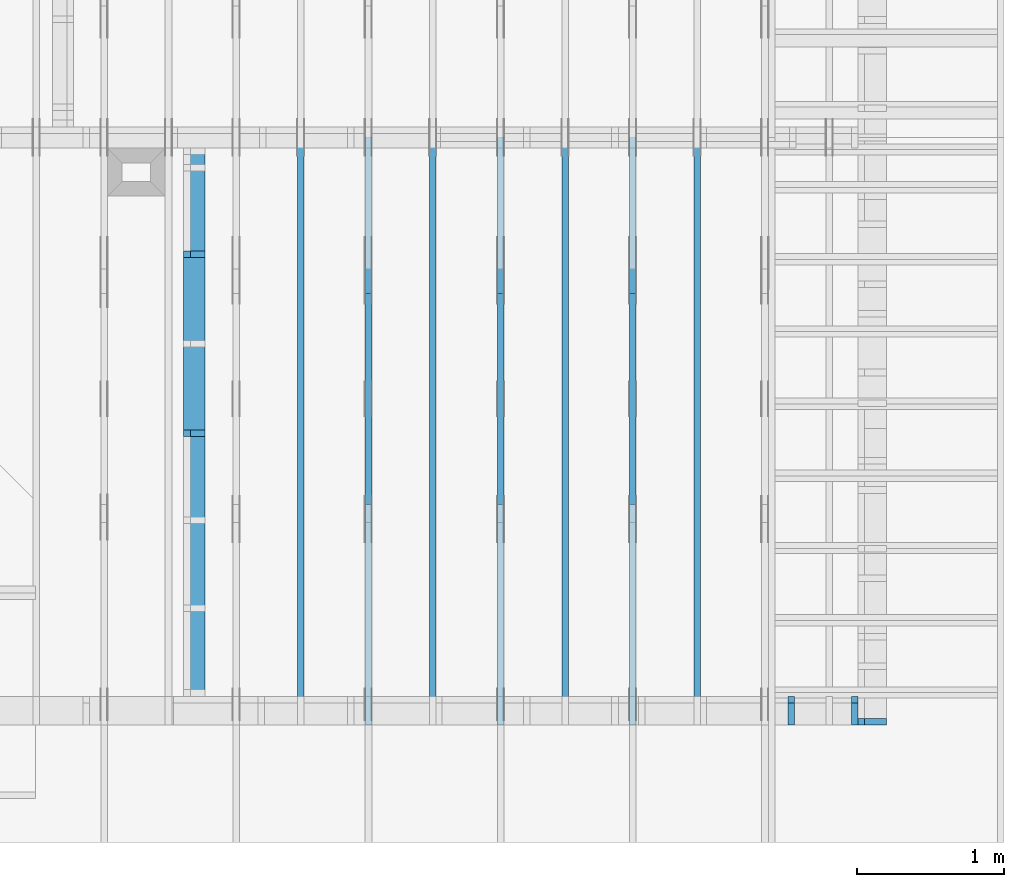
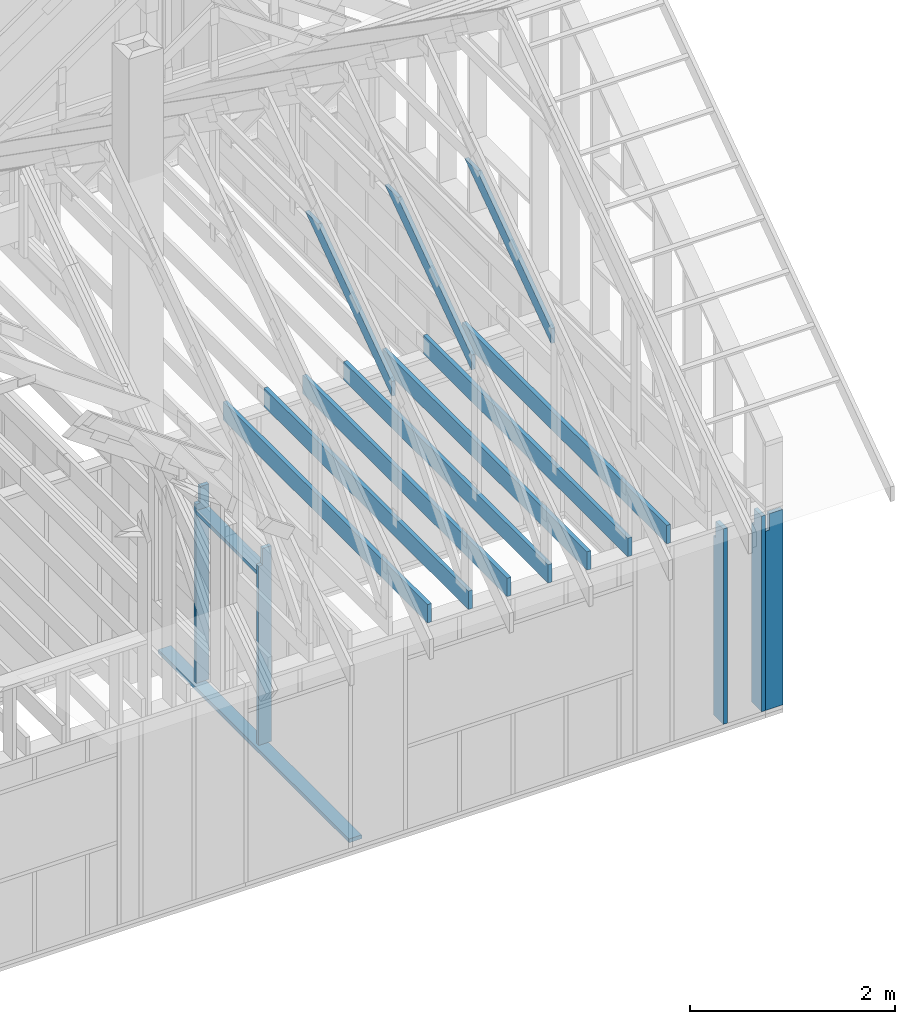
# One storey, part 21 of 70: 17 members, 10 elements without a shape of their own.
"""IFC2X3 building model written with IfcOpenShell, lengths in millimetres."""

from ifc_helpers import new_model, si_unit, frame, origin, origin_with_axes, origin_2d, place, context, project, spatial, faceted_brep, element, aggregate, save


model = new_model("IFC2X3")

# Units and contexts
model_context = context("Model", 3, precision=1e-05, world=origin())
plan_context = context("Plan", 2, precision=1e-05, world=origin_2d())
ifc_project = project(units=[si_unit("LENGTHUNIT", "METRE", prefix="MILLI"), si_unit("AREAUNIT", "SQUARE_METRE"), si_unit("VOLUMEUNIT", "CUBIC_METRE"), si_unit("SOLIDANGLEUNIT", "STERADIAN"), si_unit("PLANEANGLEUNIT", "RADIAN"), si_unit("MASSUNIT", "GRAM"), si_unit("TIMEUNIT", "SECOND"), si_unit("THERMODYNAMICTEMPERATUREUNIT", "DEGREE_CELSIUS"), si_unit("LUMINOUSINTENSITYUNIT", "LUMEN")], contexts=[model_context, plan_context])

# Site, building, storey
site_placement = place(None, origin_with_axes())
site = spatial("IfcSite", under=ifc_project, at=site_placement, CompositionType="ELEMENT")
building_placement = place(site_placement, origin_with_axes())
building = spatial("IfcBuilding", under=site, at=building_placement, Name="Layout 1", CompositionType="ELEMENT")
storey_placement = place(building_placement, origin_with_axes())
storey = spatial("IfcBuildingStorey", under=building, at=storey_placement, Name="Storey 1", CompositionType="ELEMENT", Elevation=0.0)

# Assembly, members
assembly_1_placement = place(storey_placement, frame((-48.55339059325575, 0.0, -2470.0), z_axis=(0.0, -1.0, 6.123031769111886e-17), x_axis=(1.0, 0.0, 0.0)))
assembly_1 = element("IfcElementAssembly", 1, at=assembly_1_placement, inside=storey, Name="VE4", AssemblyPlace="FACTORY", PredefinedType="NOTDEFINED")
member_1_placement = place(assembly_1_placement, frame((11808.553390592337, 2425.0, -195.00000000000003), z_axis=(0.0, 0.0, 1.0), x_axis=(-1.836909530733566e-16, -1.0, 0.0)))
member_1 = element("IfcMember", 2, at=member_1_placement, Name="S11", context=model_context, shape_type="Brep", body=[
    faceted_brep([(0.0, 45.0, 45.00000000000003), (195.00000000186265, 45.0, 45.00000000000005), (195.00000000186265, 0.0, 45.00000000000005), (0.0, 0.0, 45.00000000000003), (195.00000000186265, -2.1311460639909362e-46, 2.842170943040401e-14), (195.00000000186265, -3.3742366240998114e-31, 45.00000000000003), (195.00000000186265, 45.0, 45.00000000000003), (195.00000000186265, 45.0, 2.842170943040401e-14), (2.7553642961003504e-15, -3.3742366240998114e-31, 45.00000000000003), (1.193991194976818e-14, -1.4621692037765842e-30, 195.00000000000003), (1.7450640541968876e-14, 45.0, 195.00000000000003), (8.266092888301048e-15, 45.0, 45.00000000000003), (2335.0, -4.2891837542628763e-13, 2.842170943040403e-14), (2335.0, -4.1697846347651946e-13, 195.00000000000003), (2.1932538056648764e-30, 1.193991194976818e-14, 195.00000000000003), (5.061354936149717e-31, 2.7553642961003504e-15, 45.00000000000003), (195.00000000186265, -3.306437155354634e-14, 45.00000000000003), (195.00000000186265, -3.5819735849646686e-14, 2.842170943040401e-14), (-1.6871183120499057e-31, 45.0, 45.00000000000003), (-7.310846018882921e-31, 44.999999999999986, 195.00000000000003), (2335.0, 44.999999999999844, 195.00000000000003), (2335.0, 44.99999999999986, 2.8421709430403998e-14), (195.00000000186265, 44.999999999999986, 2.842170943040401e-14), (195.00000000186265, 44.999999999999986, 45.00000000000003), (2335.0, 45.0, 0.0), (2335.0, 45.0, 195.00000000000003), (2335.0, 0.0, 195.00000000000003), (2335.0, 0.0, 0.0), (2335.0, 45.0, 195.00000000000003), (0.0, 45.0, 195.00000000000003), (0.0, 0.0, 195.00000000000003), (2335.0, 0.0, 195.00000000000003), (195.00000000186265, 45.0, 5.2301533330168465e-14), (2335.0, 45.0, 3.143672930479291e-13), (2335.0, 0.0, 3.143672930479291e-13), (195.00000000186265, 0.0, 5.2301533330168465e-14)], [[[0, 1, 2, 3]], [[4, 5, 6, 7]], [[8, 9, 10, 11]], [[12, 13, 14, 15, 16, 17]], [[18, 19, 20, 21, 22, 23]], [[24, 25, 26, 27]], [[28, 29, 30, 31]], [[32, 33, 34, 35]]]),
])
member_2_placement = place(assembly_1_placement, frame((11377.500000001819, 2425.0, -195.0), z_axis=(0.0, 0.0, 1.0), x_axis=(-1.836909530733566e-16, -1.0, 0.0)))
member_2 = element("IfcMember", 3, at=member_2_placement, Name="S11", context=model_context, shape_type="Brep", body=[
    faceted_brep([(0.0, 45.0, 45.0), (195.00000000186265, 45.0, 45.00000000000002), (195.00000000186265, 0.0, 45.00000000000002), (0.0, 0.0, 45.0), (195.00000000186265, 0.0, 0.0), (195.00000000186265, -3.3742366240998092e-31, 45.0), (195.00000000186265, 45.00000000000182, 45.0), (195.00000000186265, 45.00000000000182, 0.0), (2.755364296100349e-15, -3.3742366240998092e-31, 45.0), (1.1939911949768178e-14, -1.462169203776584e-30, 195.0), (1.7450640541968876e-14, 45.0, 195.0), (8.266092888301046e-15, 45.0, 45.0), (2335.0, -4.2891837542628763e-13, 2.626280839091018e-29), (2335.0, -4.1697846347651946e-13, 195.0), (2.193253805664876e-30, 1.1939911949768178e-14, 195.0), (5.061354936149714e-31, 2.755364296100349e-15, 45.0), (195.00000000186265, -3.306437155354634e-14, 45.0), (195.00000000186265, -3.5819735849646686e-14, 2.193253805685826e-30), (-1.6871183120499046e-31, 45.00000000000182, 45.0), (-7.31084601888292e-31, 45.000000000001805, 195.0), (2335.0, 45.00000000000166, 195.0), (2335.0, 45.00000000000168, -8.67746995743113e-30), (195.00000000186265, 45.000000000001805, -7.888609052210118e-31), (195.00000000186265, 45.000000000001805, 45.0), (2335.0, 45.00000000001455, 0.0), (2335.0, 45.00000000001455, 195.0), (2335.0, 0.0, 195.0), (2335.0, 0.0, 0.0), (2335.0, 45.00000000001455, 195.0), (0.0, 45.00000000001455, 195.0), (0.0, 0.0, 195.0), (2335.0, 0.0, 195.0), (195.00000000186265, 45.00000000000182, 2.3879823899764457e-14), (2335.0, 45.00000000000182, 2.859455836175251e-13), (2335.0, 0.0, 2.859455836175251e-13), (195.00000000186265, 0.0, 2.3879823899764457e-14)], [[[0, 1, 2, 3]], [[4, 5, 6, 7]], [[8, 9, 10, 11]], [[12, 13, 14, 15, 16, 17]], [[18, 19, 20, 21, 22, 23]], [[24, 25, 26, 27]], [[28, 29, 30, 31]], [[32, 33, 34, 35]]]),
])
aggregate(assembly_1, [member_1, member_2])

# Assembly, member
assembly_2_placement = place(storey_placement, frame((12000.0, 0.0, -2470.0), z_axis=(1.0, -6.123031769111886e-17, 6.123031769111886e-17), x_axis=(6.123031769111886e-17, 1.0, 0.0)))
assembly_2 = element("IfcElementAssembly", 4, at=assembly_2_placement, inside=storey, Name="VE5", AssemblyPlace="FACTORY", PredefinedType="NOTDEFINED")
member_3_placement = place(assembly_2_placement, frame((45.00000000000001, 90.00000000000131, -195.00000000000003), z_axis=(0.0, 0.0, 1.0), x_axis=(6.123031769111886e-17, 1.0, 0.0)))
member_3 = element("IfcMember", 5, at=member_3_placement, Name="S11", context=model_context, shape_type="Brep", body=[
    faceted_brep([(2139.999999998136, 45.000000000000135, 2.842170943040401e-14), (2139.999999998136, 45.000000000000135, 45.00000000000003), (2139.999999998136, 1.3500311979441904e-13, 45.00000000000003), (2139.999999998136, 1.3500311979441904e-13, 2.842170943040401e-14), (2139.999999998136, 45.000000000000135, 45.00000000000029), (2334.9999999999986, 45.000000000000135, 45.00000000000031), (2334.9999999999986, 1.3500311979441904e-13, 45.00000000000031), (2139.999999998136, 1.3500311979441904e-13, 45.00000000000029), (5.684341886080802e-14, 45.00000000000015, 2.842170943040401e-14), (5.684341886080802e-14, 45.000000000000135, 195.00000000000003), (2334.9999999999986, 44.99999999999999, 195.00000000000003), (2334.9999999999986, 45.0, 45.00000000000003), (2139.999999998136, 45.000000000000014, 45.00000000000003), (2139.999999998136, 45.00000000000002, 2.8421709430404e-14), (5.684341886080801e-14, 45.00000000000001, 2.8421709430404014e-14), (2139.999999998136, 45.00000000000001, 2.904874691481645e-13), (2139.999999998136, 1.3500311979441904e-13, 2.904874691481645e-13), (5.684341886080801e-14, 1.3500311979441904e-13, 2.8421709430404014e-14), (5.684341886080802e-14, 0.0, 0.0), (1.120820287709573e-13, 9.135892724562769e-29, 195.00000000000003), (3.7656699590146706e-14, 45.000000000000014, 195.00000000000003), (-1.7581910320002584e-14, 45.000000000000014, 4.9805142853428224e-30), (2334.9999999999986, -2.91159891335768e-13, 45.00000000000003), (2334.9999999999986, -2.8197534368210017e-13, 195.00000000000003), (5.684341886080802e-14, 1.4694303174418721e-13, 195.00000000000003), (5.684341886080802e-14, 1.3500311979441904e-13, 2.8421709430404004e-14), (2139.999999998136, -2.5809551978222166e-13, 2.842170943040403e-14), (2139.999999998136, -2.553401554861213e-13, 45.00000000000003), (2334.9999999999986, 45.000000000000156, 45.00000000000003), (2334.9999999999986, 45.000000000000156, 195.00000000000003), (2334.9999999999986, 1.5631940186722204e-13, 195.00000000000003), (2334.9999999999986, 1.5631940186722204e-13, 45.00000000000003), (2334.9999999999986, 45.00000000000015, 195.00000000000003), (5.684341886080802e-14, 45.00000000000015, 195.00000000000003), (5.684341886080802e-14, 7.105427357601002e-15, 195.00000000000003), (2334.9999999999986, 7.105427357601002e-15, 195.00000000000003)], [[[0, 1, 2, 3]], [[4, 5, 6, 7]], [[8, 9, 10, 11, 12, 13]], [[14, 15, 16, 17]], [[18, 19, 20, 21]], [[22, 23, 24, 25, 26, 27]], [[28, 29, 30, 31]], [[32, 33, 34, 35]]]),
])
aggregate(assembly_2, [member_3])

assembly_3_placement = place(storey_placement, frame((7988.750000000147, 8000.0, 1.3776821480501744e-15), z_axis=(-1.0, 1.836909530733566e-16, 6.123031769111886e-17), x_axis=(-1.836909530733566e-16, -1.0, 0.0)))
assembly_3 = element("IfcElementAssembly", 6, at=assembly_3_placement, inside=storey, Name="MB1", AssemblyPlace="FACTORY", PredefinedType="TRUSS")
member_4_placement = place(assembly_3_placement, frame((8000.000000000001, 220.0, -45.0), z_axis=(0.0, 0.0, 1.0), x_axis=(-1.0, 1.2246063538223773e-16, 0.0)))
member_4 = element("IfcMember", 7, at=member_4_placement, Name="B3", context=model_context, shape_type="Brep", body=[
    faceted_brep([(4000.0000000000005, 220.0000000000005, 45.0), (0.0, 220.0000000000005, 45.0), (0.0, 0.0, 45.0), (4000.0000000000005, 0.0, 45.0), (0.0, 220.0000000000005, 0.0), (4000.0000000000005, 220.0000000000005, 4.89842541528951e-13), (4000.0000000000005, 0.0, 4.89842541528951e-13), (0.0, 0.0, 0.0), (0.0, 0.0, 0.0), (2.755364296100349e-15, -3.3742366240998092e-31, 45.0), (2.969670408019265e-14, 220.0, 45.0), (2.69413397840923e-14, 220.0, -1.6496267940043512e-30), (4000.0000000000005, -7.347638122934265e-13, 7.631468701413364e-29), (4000.0000000000005, -7.320084479973261e-13, 45.0), (5.061354936149714e-31, 2.755364296100349e-15, 45.0), (0.0, 0.0, 0.0), (4000.0000000000005, 220.0000000000005, 0.0), (4000.0000000000005, 220.0000000000005, 45.0), (4000.0000000000005, 5.115907697472721e-13, 45.0), (4000.0000000000005, 5.115907697472721e-13, 0.0), (0.0, 220.0, 0.0), (0.0, 220.0, 45.0), (4000.0000000000005, 220.00000000000065, 45.0), (4000.0000000000005, 220.00000000000065, 7.888609052210118e-30)], [[[0, 1, 2, 3]], [[4, 5, 6, 7]], [[8, 9, 10, 11]], [[12, 13, 14, 15]], [[16, 17, 18, 19]], [[20, 21, 22, 23]]]),
])
aggregate(assembly_3, [member_4])

assembly_4_placement = place(storey_placement, frame((8888.750000000146, 8000.0, 1.3776821480501744e-15), z_axis=(-1.0, 1.836909530733566e-16, 6.123031769111886e-17), x_axis=(-1.836909530733566e-16, -1.0, 0.0)))
assembly_4 = element("IfcElementAssembly", 8, at=assembly_4_placement, inside=storey, Name="MB1", AssemblyPlace="FACTORY", PredefinedType="TRUSS")
member_5_placement = place(assembly_4_placement, frame((8000.000000000001, 220.0, -45.0), z_axis=(0.0, 0.0, 1.0), x_axis=(-1.0, 1.2246063538223773e-16, 0.0)))
member_5 = element("IfcMember", 9, at=member_5_placement, Name="B3", context=model_context, shape_type="Brep", body=[
    faceted_brep([(4000.0000000000005, 220.0000000000005, 45.0), (0.0, 220.0000000000005, 45.0), (0.0, 0.0, 45.0), (4000.0000000000005, 0.0, 45.0), (0.0, 220.0000000000005, 0.0), (4000.0000000000005, 220.0000000000005, 4.89842541528951e-13), (4000.0000000000005, 0.0, 4.89842541528951e-13), (0.0, 0.0, 0.0), (0.0, 0.0, 0.0), (2.755364296100349e-15, -3.3742366240998092e-31, 45.0), (2.969670408019265e-14, 220.0, 45.0), (2.69413397840923e-14, 220.0, -1.6496267940043512e-30), (4000.0000000000005, -7.347638122934265e-13, 7.631468701413364e-29), (4000.0000000000005, -7.320084479973261e-13, 45.0), (5.061354936149714e-31, 2.755364296100349e-15, 45.0), (0.0, 0.0, 0.0), (4000.0000000000005, 220.0000000000005, 0.0), (4000.0000000000005, 220.0000000000005, 45.0), (4000.0000000000005, 5.115907697472721e-13, 45.0), (4000.0000000000005, 5.115907697472721e-13, 0.0), (0.0, 220.0, 0.0), (0.0, 220.0, 45.0), (4000.0000000000005, 220.00000000000065, 45.0), (4000.0000000000005, 220.00000000000065, 7.888609052210118e-30)], [[[0, 1, 2, 3]], [[4, 5, 6, 7]], [[8, 9, 10, 11]], [[12, 13, 14, 15]], [[16, 17, 18, 19]], [[20, 21, 22, 23]]]),
])
aggregate(assembly_4, [member_5])

assembly_5_placement = place(storey_placement, frame((9788.750000000146, 8000.0, 1.3776821480501744e-15), z_axis=(-1.0, 1.836909530733566e-16, 6.123031769111886e-17), x_axis=(-1.836909530733566e-16, -1.0, 0.0)))
assembly_5 = element("IfcElementAssembly", 10, at=assembly_5_placement, inside=storey, Name="MB1", AssemblyPlace="FACTORY", PredefinedType="TRUSS")
member_6_placement = place(assembly_5_placement, frame((8000.000000000001, 220.0, -45.0), z_axis=(0.0, 0.0, 1.0), x_axis=(-1.0, 1.2246063538223773e-16, 0.0)))
member_6 = element("IfcMember", 11, at=member_6_placement, Name="B3", context=model_context, shape_type="Brep", body=[
    faceted_brep([(4000.0000000000005, 220.0000000000005, 45.0), (0.0, 220.0000000000005, 45.0), (0.0, 0.0, 45.0), (4000.0000000000005, 0.0, 45.0), (0.0, 220.0000000000005, 0.0), (4000.0000000000005, 220.0000000000005, 4.89842541528951e-13), (4000.0000000000005, 0.0, 4.89842541528951e-13), (0.0, 0.0, 0.0), (0.0, 0.0, 0.0), (2.755364296100349e-15, -3.3742366240998092e-31, 45.0), (2.969670408019265e-14, 220.0, 45.0), (2.69413397840923e-14, 220.0, -1.6496267940043512e-30), (4000.0000000000005, -7.347638122934265e-13, 7.631468701413364e-29), (4000.0000000000005, -7.320084479973261e-13, 45.0), (5.061354936149714e-31, 2.755364296100349e-15, 45.0), (0.0, 0.0, 0.0), (4000.0000000000005, 220.0000000000005, 0.0), (4000.0000000000005, 220.0000000000005, 45.0), (4000.0000000000005, 5.115907697472721e-13, 45.0), (4000.0000000000005, 5.115907697472721e-13, 0.0), (0.0, 220.0, 0.0), (0.0, 220.0, 45.0), (4000.0000000000005, 220.00000000000065, 45.0), (4000.0000000000005, 220.00000000000065, 7.888609052210118e-30)], [[[0, 1, 2, 3]], [[4, 5, 6, 7]], [[8, 9, 10, 11]], [[12, 13, 14, 15]], [[16, 17, 18, 19]], [[20, 21, 22, 23]]]),
])
aggregate(assembly_5, [member_6])

assembly_6_placement = place(storey_placement, frame((10688.750000000146, 8000.0, 1.3776821480501744e-15), z_axis=(-1.0, 1.836909530733566e-16, 6.123031769111886e-17), x_axis=(-1.836909530733566e-16, -1.0, 0.0)))
assembly_6 = element("IfcElementAssembly", 12, at=assembly_6_placement, inside=storey, Name="MB1", AssemblyPlace="FACTORY", PredefinedType="TRUSS")
member_7_placement = place(assembly_6_placement, frame((8000.000000000001, 220.0, -45.0), z_axis=(0.0, 0.0, 1.0), x_axis=(-1.0, 1.2246063538223773e-16, 0.0)))
member_7 = element("IfcMember", 13, at=member_7_placement, Name="B3", context=model_context, shape_type="Brep", body=[
    faceted_brep([(4000.0000000000005, 220.0000000000005, 45.0), (0.0, 220.0000000000005, 45.0), (0.0, 0.0, 45.0), (4000.0000000000005, 0.0, 45.0), (0.0, 220.0000000000005, 0.0), (4000.0000000000005, 220.0000000000005, 4.89842541528951e-13), (4000.0000000000005, 0.0, 4.89842541528951e-13), (0.0, 0.0, 0.0), (0.0, 0.0, 0.0), (2.755364296100349e-15, -3.3742366240998092e-31, 45.0), (2.969670408019265e-14, 220.0, 45.0), (2.69413397840923e-14, 220.0, -1.6496267940043512e-30), (4000.0000000000005, -7.347638122934265e-13, 7.631468701413364e-29), (4000.0000000000005, -7.320084479973261e-13, 45.0), (5.061354936149714e-31, 2.755364296100349e-15, 45.0), (0.0, 0.0, 0.0), (4000.0000000000005, 220.0000000000005, 0.0), (4000.0000000000005, 220.0000000000005, 45.0), (4000.0000000000005, 5.115907697472721e-13, 45.0), (4000.0000000000005, 5.115907697472721e-13, 0.0), (0.0, 220.0, 0.0), (0.0, 220.0, 45.0), (4000.0000000000005, 220.00000000000065, 45.0), (4000.0000000000005, 220.00000000000065, 7.888609052210118e-30)], [[[0, 1, 2, 3]], [[4, 5, 6, 7]], [[8, 9, 10, 11]], [[12, 13, 14, 15]], [[16, 17, 18, 19]], [[20, 21, 22, 23]]]),
])
aggregate(assembly_6, [member_7])

# Assembly, members
assembly_7_placement = place(storey_placement, frame((10250.0, 8000.0, -9.081170196248781e-13), z_axis=(-1.0, 1.836909530733566e-16, 6.123031769111886e-17), x_axis=(-1.836909530733566e-16, -1.0, 0.0)))
assembly_7 = element("IfcElementAssembly", 14, at=assembly_7_placement, inside=storey, Name="T3", AssemblyPlace="FACTORY", PredefinedType="TRUSS")
member_8_placement = place(assembly_7_placement, frame((7999.999999999999, 220.0, -45.0), z_axis=(0.0, 0.0, 1.0), x_axis=(-1.0, 1.2246063538223773e-16, 0.0)))
member_8 = element("IfcMember", 15, at=member_8_placement, Name="B3", context=model_context, shape_type="Brep", body=[
    faceted_brep([(3999.9999999999995, 220.00000000000048, 45.0), (0.0, 220.00000000000048, 45.0), (0.0, 0.0, 45.0), (3999.9999999999995, 0.0, 45.0), (0.0, 220.00000000000048, 0.0), (3999.9999999999995, 220.00000000000048, 4.898425415289508e-13), (3999.9999999999995, 0.0, 4.898425415289508e-13), (0.0, 0.0, 0.0), (0.0, 0.0, 0.0), (2.755364296100349e-15, -3.3742366240998092e-31, 45.0), (2.969670408019265e-14, 220.0, 45.0), (2.69413397840923e-14, 220.0, -1.6496267940043512e-30), (3999.9999999999995, -7.347638122934263e-13, 7.457441671638533e-29), (3999.9999999999995, -7.320084479973259e-13, 45.0), (5.061354936149714e-31, 2.755364296100349e-15, 45.0), (0.0, 0.0, 0.0), (3999.9999999999995, 220.00000000000048, 0.0), (3999.9999999999995, 220.00000000000048, 45.0), (3999.9999999999995, 4.831690603168681e-13, 45.0), (3999.9999999999995, 4.831690603168681e-13, 0.0), (0.0, 220.0, 0.0), (0.0, 220.0, 45.0), (3999.9999999999995, 220.00000000000065, 45.0), (3999.9999999999995, 220.00000000000065, 9.466330862652142e-30)], [[[0, 1, 2, 3]], [[4, 5, 6, 7]], [[8, 9, 10, 11]], [[12, 13, 14, 15]], [[16, 17, 18, 19]], [[20, 21, 22, 23]]]),
])
member_9_placement = place(assembly_7_placement, frame((6583.168583270521, 1754.024964554012, -44.99999999999999), z_axis=(0.0, 0.0, 1.0), x_axis=(-0.8191520442890866, 0.5735764363509106, 0.0)))
member_9 = element("IfcMember", 16, at=member_9_placement, Name="SC5", context=model_context, shape_type="Brep", body=[
    faceted_brep([(2065.552220741256, 145.00000000323507, 45.0), (0.0, 145.00000000323507, 45.0), (101.53009304067928, 0.0, 45.0), (1858.4707597638994, 0.0, 45.0), (0.0, 145.00000000323507, 0.0), (2065.552220741256, 145.00000000323507, 2.5294883736716636e-13), (1858.4707597638994, 0.0, 2.275895100799972e-13), (101.53009304067928, 0.0, 1.2433439704179296e-14), (101.53009304067926, -1.4210854715202004e-14, 1.2188192559213497e-30), (101.53009304067926, -1.4210854715202004e-14, 45.0), (2.842170943040401e-14, 145.0000000003174, 45.0), (2.842170943040401e-14, 145.0000000003174, -8.457017451291223e-31), (1858.4707597638994, 3.6386987741452655e-09, 1.1604838111769461e-29), (1858.4707597638994, 3.6387015295095616e-09, 45.0), (101.53009304067928, -7.598718304623376e-15, 45.0), (101.53009304067928, -1.0354082600723725e-14, 6.339837670416306e-31), (2065.552220741256, 145.00000000323575, -3.7865323450608567e-29), (2065.552220741256, 145.00000000323575, 45.0), (1858.4707597638994, 3.639456735982094e-09, 45.0), (1858.4707597638994, 3.639456735982094e-09, -3.7865323450608567e-29), (0.0, 145.0000000003174, 0.0), (0.0, 145.0000000003174, 45.0), (2065.552220741256, 145.00000000323564, 45.0), (2065.552220741256, 145.00000000323564, 3.6287601640166543e-29)], [[[0, 1, 2, 3]], [[4, 5, 6, 7]], [[8, 9, 10, 11]], [[12, 13, 14, 15]], [[16, 17, 18, 19]], [[20, 21, 22, 23]]]),
])
aggregate(assembly_7, [member_8, member_9])

assembly_8_placement = place(storey_placement, frame((9350.0, 8000.0, -9.081170196248781e-13), z_axis=(-1.0, 1.836909530733566e-16, 6.123031769111886e-17), x_axis=(-1.836909530733566e-16, -1.0, 0.0)))
assembly_8 = element("IfcElementAssembly", 17, at=assembly_8_placement, inside=storey, Name="T3", AssemblyPlace="FACTORY", PredefinedType="TRUSS")
member_10_placement = place(assembly_8_placement, frame((7999.999999999999, 220.0, -45.0), z_axis=(0.0, 0.0, 1.0), x_axis=(-1.0, 1.2246063538223773e-16, 0.0)))
member_10 = element("IfcMember", 18, at=member_10_placement, Name="B3", context=model_context, shape_type="Brep", body=[
    faceted_brep([(3999.9999999999995, 220.00000000000048, 45.0), (0.0, 220.00000000000048, 45.0), (0.0, 0.0, 45.0), (3999.9999999999995, 0.0, 45.0), (0.0, 220.00000000000048, 0.0), (3999.9999999999995, 220.00000000000048, 4.898425415289508e-13), (3999.9999999999995, 0.0, 4.898425415289508e-13), (0.0, 0.0, 0.0), (0.0, 0.0, 0.0), (2.755364296100349e-15, -3.3742366240998092e-31, 45.0), (2.969670408019265e-14, 220.0, 45.0), (2.69413397840923e-14, 220.0, -1.6496267940043512e-30), (3999.9999999999995, -7.347638122934263e-13, 7.457441671638533e-29), (3999.9999999999995, -7.320084479973259e-13, 45.0), (5.061354936149714e-31, 2.755364296100349e-15, 45.0), (0.0, 0.0, 0.0), (3999.9999999999995, 220.00000000000048, 0.0), (3999.9999999999995, 220.00000000000048, 45.0), (3999.9999999999995, 4.831690603168681e-13, 45.0), (3999.9999999999995, 4.831690603168681e-13, 0.0), (0.0, 220.0, 0.0), (0.0, 220.0, 45.0), (3999.9999999999995, 220.00000000000065, 45.0), (3999.9999999999995, 220.00000000000065, 9.466330862652142e-30)], [[[0, 1, 2, 3]], [[4, 5, 6, 7]], [[8, 9, 10, 11]], [[12, 13, 14, 15]], [[16, 17, 18, 19]], [[20, 21, 22, 23]]]),
])
member_11_placement = place(assembly_8_placement, frame((6583.168583270521, 1754.024964554012, -44.99999999999999), z_axis=(0.0, 0.0, 1.0), x_axis=(-0.8191520442890866, 0.5735764363509106, 0.0)))
member_11 = element("IfcMember", 19, at=member_11_placement, Name="SC5", context=model_context, shape_type="Brep", body=[
    faceted_brep([(2065.552220741256, 145.00000000323507, 45.0), (0.0, 145.00000000323507, 45.0), (101.53009304067928, 0.0, 45.0), (1858.4707597638994, 0.0, 45.0), (0.0, 145.00000000323507, 0.0), (2065.552220741256, 145.00000000323507, 2.5294883736716636e-13), (1858.4707597638994, 0.0, 2.275895100799972e-13), (101.53009304067928, 0.0, 1.2433439704179296e-14), (101.53009304067926, -1.4210854715202004e-14, 1.2188192559213497e-30), (101.53009304067926, -1.4210854715202004e-14, 45.0), (2.842170943040401e-14, 145.0000000003174, 45.0), (2.842170943040401e-14, 145.0000000003174, -8.457017451291223e-31), (1858.4707597638994, 3.6386987741452655e-09, 1.1604838111769461e-29), (1858.4707597638994, 3.6387015295095616e-09, 45.0), (101.53009304067928, -7.598718304623376e-15, 45.0), (101.53009304067928, -1.0354082600723725e-14, 6.339837670416306e-31), (2065.552220741256, 145.00000000323575, -3.7865323450608567e-29), (2065.552220741256, 145.00000000323575, 45.0), (1858.4707597638994, 3.639456735982094e-09, 45.0), (1858.4707597638994, 3.639456735982094e-09, -3.7865323450608567e-29), (0.0, 145.0000000003174, 0.0), (0.0, 145.0000000003174, 45.0), (2065.552220741256, 145.00000000323564, 45.0), (2065.552220741256, 145.00000000323564, 3.6287601640166543e-29)], [[[0, 1, 2, 3]], [[4, 5, 6, 7]], [[8, 9, 10, 11]], [[12, 13, 14, 15]], [[16, 17, 18, 19]], [[20, 21, 22, 23]]]),
])
aggregate(assembly_8, [member_10, member_11])

assembly_9_placement = place(storey_placement, frame((8450.0, 8000.0, -9.081170196248781e-13), z_axis=(-1.0, 1.836909530733566e-16, 6.123031769111886e-17), x_axis=(-1.836909530733566e-16, -1.0, 0.0)))
assembly_9 = element("IfcElementAssembly", 20, at=assembly_9_placement, inside=storey, Name="T3", AssemblyPlace="FACTORY", PredefinedType="TRUSS")
member_12_placement = place(assembly_9_placement, frame((7999.999999999999, 220.0, -45.0), z_axis=(0.0, 0.0, 1.0), x_axis=(-1.0, 1.2246063538223773e-16, 0.0)))
member_12 = element("IfcMember", 21, at=member_12_placement, Name="B3", context=model_context, shape_type="Brep", body=[
    faceted_brep([(3999.9999999999995, 220.00000000000048, 45.0), (0.0, 220.00000000000048, 45.0), (0.0, 0.0, 45.0), (3999.9999999999995, 0.0, 45.0), (0.0, 220.00000000000048, 0.0), (3999.9999999999995, 220.00000000000048, 4.898425415289508e-13), (3999.9999999999995, 0.0, 4.898425415289508e-13), (0.0, 0.0, 0.0), (0.0, 0.0, 0.0), (2.755364296100349e-15, -3.3742366240998092e-31, 45.0), (2.969670408019265e-14, 220.0, 45.0), (2.69413397840923e-14, 220.0, -1.6496267940043512e-30), (3999.9999999999995, -7.347638122934263e-13, 7.457441671638533e-29), (3999.9999999999995, -7.320084479973259e-13, 45.0), (5.061354936149714e-31, 2.755364296100349e-15, 45.0), (0.0, 0.0, 0.0), (3999.9999999999995, 220.00000000000048, 0.0), (3999.9999999999995, 220.00000000000048, 45.0), (3999.9999999999995, 4.831690603168681e-13, 45.0), (3999.9999999999995, 4.831690603168681e-13, 0.0), (0.0, 220.0, 0.0), (0.0, 220.0, 45.0), (3999.9999999999995, 220.00000000000065, 45.0), (3999.9999999999995, 220.00000000000065, 9.466330862652142e-30)], [[[0, 1, 2, 3]], [[4, 5, 6, 7]], [[8, 9, 10, 11]], [[12, 13, 14, 15]], [[16, 17, 18, 19]], [[20, 21, 22, 23]]]),
])
member_13_placement = place(assembly_9_placement, frame((6583.168583270521, 1754.024964554012, -44.99999999999999), z_axis=(0.0, 0.0, 1.0), x_axis=(-0.8191520442890866, 0.5735764363509106, 0.0)))
member_13 = element("IfcMember", 22, at=member_13_placement, Name="SC5", context=model_context, shape_type="Brep", body=[
    faceted_brep([(2065.552220741256, 145.00000000323507, 45.0), (0.0, 145.00000000323507, 45.0), (101.53009304067928, 0.0, 45.0), (1858.4707597638994, 0.0, 45.0), (0.0, 145.00000000323507, 0.0), (2065.552220741256, 145.00000000323507, 2.5294883736716636e-13), (1858.4707597638994, 0.0, 2.275895100799972e-13), (101.53009304067928, 0.0, 1.2433439704179296e-14), (101.53009304067926, -1.4210854715202004e-14, 1.2188192559213497e-30), (101.53009304067926, -1.4210854715202004e-14, 45.0), (2.842170943040401e-14, 145.0000000003174, 45.0), (2.842170943040401e-14, 145.0000000003174, -8.457017451291223e-31), (1858.4707597638994, 3.6386987741452655e-09, 1.1604838111769461e-29), (1858.4707597638994, 3.6387015295095616e-09, 45.0), (101.53009304067928, -7.598718304623376e-15, 45.0), (101.53009304067928, -1.0354082600723725e-14, 6.339837670416306e-31), (2065.552220741256, 145.00000000323575, -3.7865323450608567e-29), (2065.552220741256, 145.00000000323575, 45.0), (1858.4707597638994, 3.639456735982094e-09, 45.0), (1858.4707597638994, 3.639456735982094e-09, -3.7865323450608567e-29), (0.0, 145.0000000003174, 0.0), (0.0, 145.0000000003174, 45.0), (2065.552220741256, 145.00000000323564, 45.0), (2065.552220741256, 145.00000000323564, 3.6287601640166543e-29)], [[[0, 1, 2, 3]], [[4, 5, 6, 7]], [[8, 9, 10, 11]], [[12, 13, 14, 15]], [[16, 17, 18, 19]], [[20, 21, 22, 23]]]),
])
aggregate(assembly_9, [member_12, member_13])

assembly_10_placement = place(storey_placement, frame((7359.197265625001, 195.0, -2470.0), z_axis=(1.0, -6.123031769111886e-17, 6.123031769111886e-17), x_axis=(6.123031769111886e-17, 1.0, 0.0)))
assembly_10 = element("IfcElementAssembly", 23, at=assembly_10_placement, inside=storey, Name="VE10", AssemblyPlace="FACTORY", PredefinedType="NOTDEFINED")
member_14_placement = place(assembly_10_placement, frame((3732.5000000000005, 45.0, -145.0), z_axis=(0.0, 0.0, 1.0), x_axis=(-1.0, 1.2246063538223773e-16, 0.0)))
member_14 = element("IfcMember", 24, at=member_14_placement, Name="P15", context=model_context, shape_type="Brep", body=[
    faceted_brep([(3732.5000000000005, 45.000000000000455, 145.0), (0.0, 45.000000000000455, 145.0), (0.0, 0.0, 145.0), (3732.5000000000005, 0.0, 145.0), (0.0, 45.000000000000455, 0.0), (3732.5000000000005, 45.000000000000455, 4.570843215642024e-13), (3732.5000000000005, 0.0, 4.570843215642024e-13), (0.0, 0.0, 0.0), (0.0, 0.0, 0.0), (8.878396065212235e-15, -1.0872540233210496e-30, 145.0), (1.4389124657641033e-14, 45.000000001862645, 145.0), (5.510728592428798e-15, 45.000000001862645, -3.3742366242394762e-31), (3732.5000000000005, -6.856264823463036e-13, 6.982545209548136e-29), (3732.5000000000005, -6.767480862810913e-13, 145.0), (1.6308810349815745e-30, 8.878396065212235e-15, 145.0), (0.0, 0.0, 0.0), (3732.5000000000005, 45.000000000000455, 0.0), (3732.5000000000005, 45.000000000000455, 145.0), (3732.5000000000005, 4.547473508864641e-13, 145.0), (3732.5000000000005, 4.547473508864641e-13, 0.0), (0.0, 45.000000001862645, 0.0), (-3.2311742677852644e-27, 45.00000000186264, 145.0), (3732.5000000000005, 45.000000000000135, 145.0), (3732.5000000000005, 45.00000000000014, -1.932709217791479e-29)], [[[0, 1, 2, 3]], [[4, 5, 6, 7]], [[8, 9, 10, 11]], [[12, 13, 14, 15]], [[16, 17, 18, 19]], [[20, 21, 22, 23]]]),
])
member_15_placement = place(assembly_10_placement, frame((1767.500000003667, 2425.0, -145.00000000000003), z_axis=(0.0, 0.0, 1.0), x_axis=(-1.836909530733566e-16, -1.0, 0.0)))
member_15 = element("IfcMember", 25, at=member_15_placement, Name="T15", context=model_context, shape_type="Brep", body=[
    faceted_brep([(0.0, 45.0, 45.00000000000003), (195.00000000186265, 45.0, 45.00000000000005), (195.00000000186265, 0.0, 45.00000000000005), (0.0, 0.0, 45.00000000000003), (195.00000000186265, 1.1368683772161603e-12, 2.842170943040401e-14), (195.00000000186265, 1.1368683772161603e-12, 45.00000000000003), (195.00000000186265, 45.0, 45.00000000000003), (195.00000000186265, 45.0, 2.842170943040401e-14), (2.7553642961003504e-15, -3.3742366240998114e-31, 45.00000000000003), (8.878396065212235e-15, -1.0872540233210496e-30, 145.0), (1.4389124657412933e-14, 45.0, 145.00000000000003), (8.266092888301048e-15, 45.0, 45.00000000000003), (2335.0, -4.2891837542628763e-13, 2.842170943040403e-14), (2335.0, -4.200399793610754e-13, 145.00000000000003), (1.6308810349815748e-30, 8.878396065212237e-15, 145.00000000000003), (5.061354936149717e-31, 2.7553642961003504e-15, 45.00000000000003), (195.00000000186265, -3.306437155354634e-14, 45.00000000000003), (195.00000000186265, -3.5819735849646686e-14, 2.842170943040401e-14), (-1.6871183120499057e-31, 45.0, 45.00000000000003), (-5.436270116605249e-31, 44.99999999999999, 145.00000000000003), (2335.0, 44.99999999999985, 145.00000000000003), (2335.0, 44.99999999999986, 2.8421709430403998e-14), (195.00000000186265, 44.999999999999986, 2.842170943040401e-14), (195.00000000186265, 44.999999999999986, 45.00000000000003), (2335.0, 45.000000000000455, 0.0), (2335.0, 45.000000000000455, 145.00000000000003), (2335.0, 1.5006662579253316e-11, 145.00000000000003), (2335.0, 1.5006662579253316e-11, 0.0), (2335.0, 45.000000000000455, 145.00000000000003), (0.0, 45.000000000000455, 145.00000000000003), (0.0, 0.0, 145.00000000000003), (2335.0, 0.0, 145.00000000000003), (195.00000000186265, 45.0, 5.2301533330168465e-14), (2335.0, 45.0, 3.143672930479291e-13), (2335.0, 1.5006662579253316e-11, 3.143672930479291e-13), (195.00000000186265, 1.5006662579253316e-11, 5.2301533330168465e-14)], [[[0, 1, 2, 3]], [[4, 5, 6, 7]], [[8, 9, 10, 11]], [[12, 13, 14, 15, 16, 17]], [[18, 19, 20, 21, 22, 23]], [[24, 25, 26, 27]], [[28, 29, 30, 31]], [[32, 33, 34, 35]]]),
])
member_16_placement = place(assembly_10_placement, frame((2987.5000000036525, 2425.0, -145.0), z_axis=(0.0, 0.0, 1.0), x_axis=(-1.836909530733566e-16, -1.0, 0.0)))
member_16 = element("IfcMember", 26, at=member_16_placement, Name="C3", context=model_context, shape_type="Brep", body=[
    faceted_brep([(0.0, 44.99999999998545, 45.0), (195.00000000186265, 44.99999999998545, 45.00000000000002), (195.00000000186265, 0.0, 45.00000000000002), (0.0, 0.0, 45.0), (195.00000000186265, 0.0, 0.0), (195.00000000186265, -3.3742366240998092e-31, 45.0), (195.00000000186265, 44.99999999998681, 45.0), (195.00000000186265, 44.99999999998681, 0.0), (2.755364296100349e-15, -3.3742366240998092e-31, 45.0), (8.878396065212235e-15, -1.0872540233210496e-30, 145.0), (1.438912465741115e-14, 44.99999999998545, 145.0), (8.266092888299264e-15, 44.99999999998545, 45.0), (2335.0, -4.2891837542628763e-13, 2.626280839091018e-29), (2335.0, -4.200399793610754e-13, 145.0), (1.6308810349815745e-30, 8.878396065212235e-15, 145.0), (5.061354936149714e-31, 2.755364296100349e-15, 45.0), (195.00000000186265, -3.306437155354634e-14, 45.0), (195.00000000186265, -3.5819735849646686e-14, 2.193253805685826e-30), (-1.6871183120499046e-31, 44.99999999998681, 45.0), (-5.436270116605248e-31, 44.999999999986805, 145.0), (2335.0, 44.99999999998666, 145.0), (2335.0, 44.99999999998667, -8.67746995743113e-30), (195.00000000186265, 44.9999999999868, -7.888609052210118e-31), (195.00000000186265, 44.9999999999868, 45.0), (2335.0, 45.000000000000455, 2.842170943040401e-14), (2335.0, 45.000000000000455, 145.0), (2335.0, 4.547473508864641e-13, 145.0), (2335.0, 4.547473508864641e-13, 0.0), (2335.0, 45.000000000000455, 145.0), (0.0, 45.000000000000455, 145.0), (0.0, 0.0, 145.0), (2335.0, 0.0, 145.0), (195.00000000186265, 44.99999999998681, 2.3879823899764457e-14), (2335.0, 44.99999999998681, 2.859455836175251e-13), (2335.0, 4.547473508864641e-13, 2.859455836175251e-13), (195.00000000186265, 4.547473508864641e-13, 2.3879823899764457e-14)], [[[0, 1, 2, 3]], [[4, 5, 6, 7]], [[8, 9, 10, 11]], [[12, 13, 14, 15, 16, 17]], [[18, 19, 20, 21, 22, 23]], [[24, 25, 26, 27]], [[28, 29, 30, 31]], [[32, 33, 34, 35]]]),
])
member_17_placement = place(assembly_10_placement, frame((2987.500000001819, 2154.9999999987776, -145.0), z_axis=(0.0, 0.0, 1.0), x_axis=(-1.0, 1.2246063538223773e-16, 0.0)))
member_17 = element("IfcMember", 27, at=member_17_placement, Name="S44", context=model_context, shape_type="Brep", body=[
    faceted_brep([(1174.9999999999852, 45.00000000001501, 145.0), (0.0, 45.00000000001501, 145.0), (0.0, 0.0, 145.0), (1174.9999999999852, 0.0, 145.0), (0.0, 45.00000000001501, 0.0), (1174.9999999999852, 45.00000000001501, 1.438912465741275e-13), (1174.9999999999852, 0.0, 1.438912465741275e-13), (0.0, 0.0, 0.0), (0.0, 0.0, 0.0), (8.878396065212235e-15, -1.0872540233210496e-30, 145.0), (1.4389124657414716e-14, 45.00000000001455, 145.0), (5.51072859220248e-15, 45.00000000001455, -3.3742366241009005e-31), (1174.9999999999852, -2.1583686986119127e-13, 4.106008487503032e-29), (1174.9999999999852, -2.0695847379597903e-13, 145.0), (1.6308810349815745e-30, 8.878396065212235e-15, 145.0), (0.0, 0.0, 0.0), (1174.9999999999852, 45.00000000001501, 0.0), (1174.9999999999852, 45.00000000001501, 145.0), (1174.9999999999852, 4.547473508864641e-13, 145.0), (1174.9999999999852, 4.547473508864641e-13, 0.0), (0.0, 45.00000000001455, 0.0), (3.1554436208840472e-30, 45.000000000014545, 145.0), (1174.9999999999852, 45.00000000001499, 145.0), (1174.9999999999852, 45.000000000015, -3.944304526105059e-31)], [[[0, 1, 2, 3]], [[4, 5, 6, 7]], [[8, 9, 10, 11]], [[12, 13, 14, 15]], [[16, 17, 18, 19]], [[20, 21, 22, 23]]]),
])
aggregate(assembly_10, [member_14, member_15, member_16, member_17])

save(model, "model.ifc")
